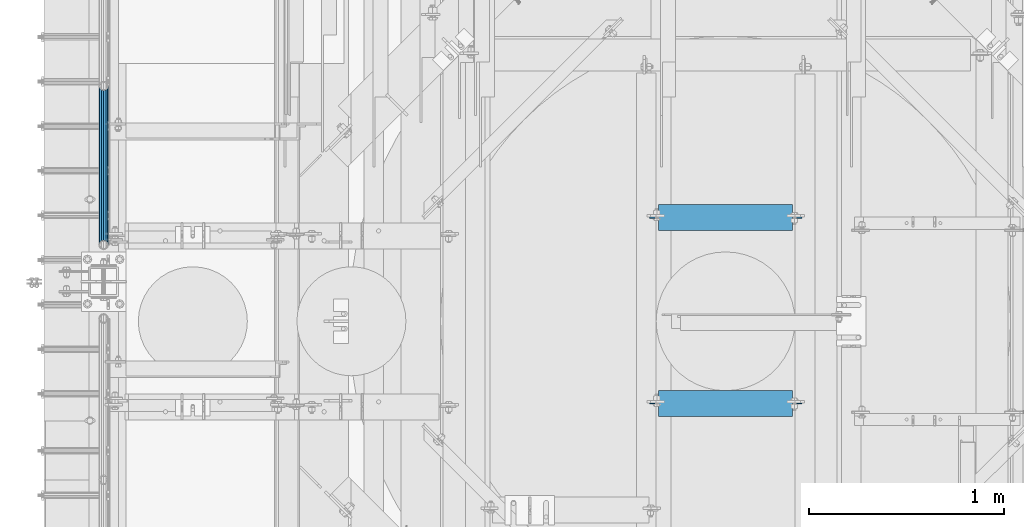
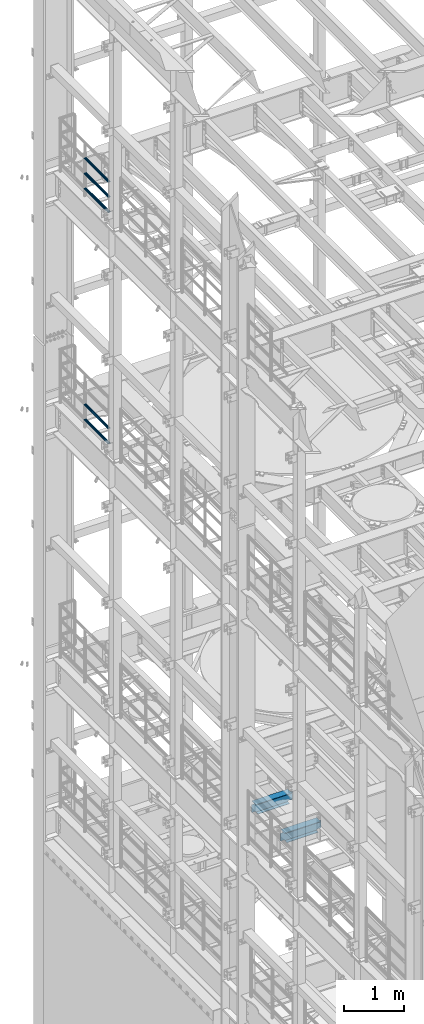
# One storey, part 1311 of 1876: 7 beams, 4 elements without a shape of their own.
"""IFC2X3 building model written with IfcOpenShell, lengths in millimetres."""

from ifc_helpers import new_model, si_unit, frame, origin_with_axes, place, context, subcontext, project, spatial, faceted_brep, material, type_object, element, aggregate, save


model = new_model("IFC2X3")

# Units and contexts
model_context = context("Model", 3, precision=1e-05, world=origin_with_axes())
body_context = subcontext(model_context, "Body", "Model", "MODEL_VIEW")
ifc_project = project(units=[si_unit("LENGTHUNIT", "METRE", prefix="MILLI"), si_unit("AREAUNIT", "SQUARE_METRE"), si_unit("VOLUMEUNIT", "CUBIC_METRE"), si_unit("MASSUNIT", "GRAM", prefix="KILO"), si_unit("TIMEUNIT", "SECOND"), si_unit("PLANEANGLEUNIT", "RADIAN"), si_unit("SOLIDANGLEUNIT", "STERADIAN"), si_unit("THERMODYNAMICTEMPERATUREUNIT", "DEGREE_CELSIUS"), si_unit("LUMINOUSINTENSITYUNIT", "LUMEN")], contexts=[model_context])

# Site, building, storey
site_placement = place(None, origin_with_axes())
site = spatial("IfcSite", under=ifc_project, at=site_placement, CompositionType="ELEMENT")
building_placement = place(site_placement, origin_with_axes())
building = spatial("IfcBuilding", under=site, at=building_placement, Name="Undefined", CompositionType="ELEMENT")
storey_placement = place(building_placement, origin_with_axes())
storey = spatial("IfcBuildingStorey", under=building, at=storey_placement, Name="Undefined", CompositionType="ELEMENT", Elevation=0.0)

# Assembly, beams
assembly_1_placement = place(storey_placement, origin_with_axes())
assembly_1 = element("IfcElementAssembly", 1, at=assembly_1_placement, inside=storey, Name="RAIL", AssemblyPlace="NOTDEFINED", PredefinedType="RIGID_FRAME")
ifc_material_1 = material()
beam_type_1 = type_object("IfcBeamType", Name="PIPE1-1/2SCH40", PredefinedType="NOTDEFINED")
beam_1_placement = place(assembly_1_placement, frame((-3.02406988339499e-11, 12686.3094, 18145.125), z_axis=(0.0, 0.0, 1.0), x_axis=(0.0, -1.0, 0.0)))
beam_1 = element("IfcBeam", 2, at=beam_1_placement, type_object=beam_type_1, material=ifc_material_1, Name="RAIL", ObjectType="PIPE1-1/2SCH40", context=body_context, shape_type="Brep", body=[
    faceted_brep([(792.499707006684, -12.0649999999996, 20.8971929933177), (792.499707006684, -12.0650000000314, 15.8661214311469), (792.006278568813, -10.2235000000001, 17.7076214311819), (789.266900000001, -9.09494701772928e-13, 20.4470000000001), (789.266900000001, -9.09494701772928e-13, 24.130000000001), (792.00627856883, 10.2235000000001, 17.7076214311819), (792.499707006684, 12.0649999999678, 15.8661214312124), (792.499707006684, 12.0649999999996, 20.8971929933177), (813.396900000002, 24.1300000000001, 0.0), (801.331900000001, 20.8971929933186, 12.0649999999987), (801.331900000001, 20.8971929933186, -12.0649999999987), (798.142328437896, 17.7076214311801, 10.2235000000001), (800.881707006714, 20.4470000000001, 0.0), (798.142328437896, 17.7076214311801, -10.2235000000001), (792.499707006684, 12.0649999999678, -15.8661214312124), (792.499707006684, 12.0649999999996, -20.8971929933177), (792.00627856883, 10.2235000000001, -17.7076214311819), (789.266900000001, 0.0, -20.4470000000001), (789.266900000001, 0.0, -24.130000000001), (792.499707006684, -12.0650000000314, -15.8661214311469), (792.499707006684, -12.0649999999996, -20.8971929933177), (792.006278568813, -10.2235000000001, -17.7076214311819), (813.396900000002, -24.1300000000319, 0.0), (801.331900000001, -20.8971929933186, -12.0649999999987), (801.331900000001, -20.8971929933186, 12.0649999999987), (798.142328437831, -17.7076214311801, -10.2235000000001), (800.881707006651, -20.4470000000001, 0.0), (798.142328437831, -17.7076214311801, 10.2235000000001), (12.0650000000064, -20.8971929933177, -12.0649999999987), (20.8971929933249, -12.0650000000005, -20.8971929933177), (0.0, 24.1299999999992, 0.0), (12.0650000000064, 20.8971929933177, -12.0649999999987), (12.0650000000064, 20.8971929933177, 12.0649999999987), (20.8971929933249, 12.0650000000005, 20.8971929933177), (24.1300000000064, 0.0, 24.130000000001), (20.8971929933249, 12.0650000000005, -20.8971929933177), (24.1300000000063, 0.0, -24.130000000001), (24.1300000000063, 0.0, -20.4470000000001), (20.8971929933249, -12.0650000000005, -15.8661214311796), (21.3906214311868, -10.2235000000001, -17.7076214311819), (21.3906214311868, 10.2235000000001, -17.7076214311819), (20.8971929933249, 12.0650000000005, -15.8661214311796), (15.2545715621445, 17.7076214311801, -10.2235000000001), (12.5151929933249, 20.4470000000001, 0.0), (15.2545715621445, 17.7076214311801, 10.2235000000001), (20.8971929933249, 12.0650000000005, 15.8661214311796), (21.3906214311868, 10.2235000000001, 17.7076214311819), (24.1300000000064, 0.0, 20.4470000000001), (21.3906214311868, -10.2235000000001, 17.7076214311819), (20.8971929933249, -12.0650000000005, 15.8661214311796), (20.8971929933249, -12.0650000000005, 20.8971929933177), (12.0650000000064, -20.8971929933177, 12.0649999999987), (0.0, -24.1299999999992, 0.0), (15.2545715621445, -17.7076214311801, 10.2235000000001), (12.5151929933249, -20.4470000000001, 0.0), (15.2545715621445, -17.7076214311801, -10.2235000000001)], [[[0, 1, 2, 3, 4]], [[4, 3, 5, 6, 7]], [[8, 9, 10]], [[7, 6, 11, 12, 13, 14, 15, 10, 9]], [[16, 17, 18, 15, 14]], [[19, 20, 18, 17, 21]], [[22, 23, 24]], [[24, 23, 20, 19, 25, 26, 27, 1, 0]], [[28, 29, 20, 23]], [[30, 31, 32]], [[33, 34, 4, 7]], [[32, 33, 7, 9]], [[30, 32, 9, 8]], [[31, 30, 8, 10]], [[35, 31, 10, 15]], [[36, 35, 15, 18]], [[29, 36, 18, 20]], [[37, 36, 29, 38, 39]], [[40, 41, 35, 36, 37]], [[32, 31, 35, 41, 42, 43, 44, 45, 33]], [[33, 45, 46, 47, 34]], [[34, 47, 48, 49, 50]], [[34, 50, 0, 4]], [[50, 51, 24, 0]], [[51, 52, 22, 24]], [[52, 28, 23, 22]], [[51, 28, 52]], [[50, 49, 53, 54, 55, 38, 29, 28, 51]], [[55, 54, 26, 25]], [[21, 39, 38, 55, 25, 19]], [[37, 39, 21, 17]], [[40, 37, 17, 16]], [[42, 41, 40, 16, 14, 13]], [[43, 42, 13, 12]], [[44, 43, 12, 11]], [[5, 46, 45, 44, 11, 6]], [[47, 46, 5, 3]], [[48, 47, 3, 2]], [[53, 49, 48, 2, 1, 27]], [[54, 53, 27, 26]]]),
])
beam_2_placement = place(assembly_1_placement, frame((-3.11501935357228e-11, 11872.9125, 18449.925), z_axis=(0.0, 0.0, -1.0), x_axis=(0.0, 1.0, 0.0)))
beam_2 = element("IfcBeam", 3, at=beam_2_placement, type_object=beam_type_1, material=ifc_material_1, Name="RAIL", ObjectType="PIPE1-1/2SCH40", context=body_context, shape_type="Brep", body=[
    faceted_brep([(0.0, 24.1299999999992, 0.0), (12.0650000000064, 20.8971929933177, -12.0649999999987), (12.0650000000064, 20.8971929933177, 12.0649999999987), (12.0650000000064, -20.8971929933177, 12.0649999999987), (12.0650000000064, -20.8971929933177, -12.0649999999987), (0.0, -24.1299999999992, 0.0), (20.8971929933249, -12.0650000000005, 20.8971929933177), (20.8971929933249, -12.0650000000005, 15.8661214311796), (15.2545715621445, -17.7076214311801, 10.2235000000001), (12.5151929933249, -20.4470000000001, 0.0), (15.2545715621445, -17.7076214311801, -10.2235000000001), (20.8971929933249, -12.0650000000005, -15.8661214311796), (20.8971929933249, -12.0650000000005, -20.8971929933177), (24.1300000000063, 0.0, -20.4470000000001), (24.1300000000063, 0.0, -24.130000000001), (21.3906214311868, -10.2235000000001, -17.7076214311819), (21.3906214311868, 10.2235000000001, -17.7076214311819), (20.8971929933249, 12.0650000000005, -15.8661214311796), (20.8971929933249, 12.0650000000005, -20.8971929933177), (15.2545715621445, 17.7076214311801, -10.2235000000001), (12.5151929933249, 20.4470000000001, 0.0), (15.2545715621445, 17.7076214311801, 10.2235000000001), (20.8971929933249, 12.0650000000005, 15.8661214311796), (20.8971929933249, 12.0650000000005, 20.8971929933177), (21.3906214311868, 10.2235000000001, 17.7076214311819), (24.1300000000064, 0.0, 20.4470000000001), (24.1300000000064, 0.0, 24.130000000001), (21.3906214311868, -10.2235000000001, 17.7076214311819), (813.396900000002, 24.1300000000001, 0.0), (801.331900000001, 20.8971929933186, -12.0649999999987), (792.499707006684, 12.0649999999996, -20.8971929933177), (813.396900000002, -24.1300000000319, 0.0), (801.331900000001, -20.8971929933186, -12.0649999999987), (801.331900000001, -20.8971929933186, 12.0649999999987), (792.499707006684, -12.0649999999996, 20.8971929933177), (792.499707006684, -12.0649999999996, -20.8971929933177), (789.266900000001, 0.0, -24.130000000001), (792.00627856883, 10.2235000000001, -17.7076214311819), (789.266900000001, 0.0, -20.4470000000001), (792.499707006684, 12.0649999999678, -15.8661214312124), (792.499707006684, -12.0650000000314, -15.8661214311469), (792.006278568813, -10.2235000000001, -17.7076214311819), (798.142328437831, -17.7076214311801, -10.2235000000001), (800.881707006651, -20.4470000000001, 0.0), (798.142328437831, -17.7076214311801, 10.2235000000001), (792.499707006684, -12.0650000000314, 15.8661214311469), (792.006278568813, -10.2235000000001, 17.7076214311819), (789.266900000001, -9.09494701772928e-13, 20.4470000000001), (789.266900000001, -9.09494701772928e-13, 24.130000000001), (792.499707006684, 12.0649999999996, 20.8971929933177), (801.331900000001, 20.8971929933186, 12.0649999999987), (792.499707006684, 12.0649999999678, 15.8661214312124), (798.142328437896, 17.7076214311801, 10.2235000000001), (800.881707006714, 20.4470000000001, 0.0), (798.142328437896, 17.7076214311801, -10.2235000000001), (792.00627856883, 10.2235000000001, 17.7076214311819)], [[[0, 1, 2]], [[3, 4, 5]], [[6, 7, 8, 9, 10, 11, 12, 4, 3]], [[13, 14, 12, 11, 15]], [[16, 17, 18, 14, 13]], [[2, 1, 18, 17, 19, 20, 21, 22, 23]], [[23, 22, 24, 25, 26]], [[26, 25, 27, 7, 6]], [[1, 0, 28, 29]], [[18, 1, 29, 30]], [[31, 32, 33]], [[6, 3, 33, 34]], [[3, 5, 31, 33]], [[5, 4, 32, 31]], [[4, 12, 35, 32]], [[12, 14, 36, 35]], [[14, 18, 30, 36]], [[37, 38, 36, 30, 39]], [[40, 35, 36, 38, 41]], [[33, 32, 35, 40, 42, 43, 44, 45, 34]], [[34, 45, 46, 47, 48]], [[26, 6, 34, 48]], [[2, 23, 49, 50]], [[23, 26, 48, 49]], [[0, 2, 50, 28]], [[28, 50, 29]], [[49, 51, 52, 53, 54, 39, 30, 29, 50]], [[48, 47, 55, 51, 49]], [[25, 24, 55, 47]], [[55, 24, 22, 21, 52, 51]], [[21, 20, 53, 52]], [[20, 19, 54, 53]], [[19, 17, 16, 37, 39, 54]], [[16, 13, 38, 37]], [[13, 15, 41, 38]], [[41, 15, 11, 10, 42, 40]], [[10, 9, 43, 42]], [[9, 8, 44, 43]], [[8, 7, 27, 46, 45, 44]], [[27, 25, 47, 46]]]),
])
beam_3_placement = place(assembly_1_placement, frame((-3.11501935357228e-11, 11872.9125, 18754.725), z_axis=(0.0, 0.0, -1.0), x_axis=(0.0, 1.0, 0.0)))
beam_3 = element("IfcBeam", 4, at=beam_3_placement, type_object=beam_type_1, material=ifc_material_1, Name="RAIL", ObjectType="PIPE1-1/2SCH40", context=body_context, shape_type="Brep", body=[
    faceted_brep([(0.0, 24.1299999999992, 0.0), (12.0650000000064, 20.8971929933177, -12.0649999999987), (12.0650000000064, 20.8971929933177, 12.0649999999987), (12.0650000000064, -20.8971929933177, 12.0649999999987), (12.0650000000064, -20.8971929933177, -12.0649999999987), (0.0, -24.1299999999992, 0.0), (20.8971929933249, -12.0650000000005, 20.8971929933177), (20.8971929933249, -12.0650000000005, 15.8661214311796), (15.2545715621445, -17.7076214311801, 10.2235000000001), (12.5151929933249, -20.4470000000001, 0.0), (15.2545715621445, -17.7076214311801, -10.2235000000001), (20.8971929933249, -12.0650000000005, -15.8661214311796), (20.8971929933249, -12.0650000000005, -20.8971929933177), (24.1300000000063, 0.0, -20.4470000000001), (24.1300000000063, 0.0, -24.130000000001), (21.3906214311868, -10.2235000000001, -17.7076214311819), (21.3906214311868, 10.2235000000001, -17.7076214311819), (20.8971929933249, 12.0650000000005, -15.8661214311796), (20.8971929933249, 12.0650000000005, -20.8971929933177), (15.2545715621445, 17.7076214311801, -10.2235000000001), (12.5151929933249, 20.4470000000001, 0.0), (15.2545715621445, 17.7076214311801, 10.2235000000001), (20.8971929933249, 12.0650000000005, 15.8661214311796), (20.8971929933249, 12.0650000000005, 20.8971929933177), (21.3906214311868, 10.2235000000001, 17.7076214311819), (24.1300000000064, 0.0, 20.4470000000001), (24.1300000000064, 0.0, 24.130000000001), (21.3906214311868, -10.2235000000001, 17.7076214311819), (813.396900000002, 24.1300000000001, 0.0), (801.331900000001, 20.8971929933186, -12.0649999999987), (792.499707006684, 12.0649999999996, -20.8971929933177), (813.396900000002, -24.1300000000319, 0.0), (801.331900000001, -20.8971929933186, -12.0649999999987), (801.331900000001, -20.8971929933186, 12.0649999999987), (792.499707006684, -12.0649999999996, 20.8971929933177), (792.499707006684, -12.0649999999996, -20.8971929933177), (789.266900000001, 0.0, -24.130000000001), (792.00627856883, 10.2235000000001, -17.7076214311819), (789.266900000001, 0.0, -20.4470000000001), (792.499707006684, 12.0649999999678, -15.8661214312124), (792.499707006684, -12.0650000000314, -15.8661214311469), (792.006278568813, -10.2235000000001, -17.7076214311819), (798.142328437831, -17.7076214311801, -10.2235000000001), (800.881707006651, -20.4470000000001, 0.0), (798.142328437831, -17.7076214311801, 10.2235000000001), (792.499707006684, -12.0650000000314, 15.8661214311469), (792.006278568813, -10.2235000000001, 17.7076214311819), (789.266900000001, -9.09494701772928e-13, 20.4470000000001), (789.266900000001, -9.09494701772928e-13, 24.130000000001), (792.499707006684, 12.0649999999996, 20.8971929933177), (801.331900000001, 20.8971929933186, 12.0649999999987), (792.499707006684, 12.0649999999678, 15.8661214312124), (798.142328437896, 17.7076214311801, 10.2235000000001), (800.881707006714, 20.4470000000001, 0.0), (798.142328437896, 17.7076214311801, -10.2235000000001), (792.00627856883, 10.2235000000001, 17.7076214311819)], [[[0, 1, 2]], [[3, 4, 5]], [[6, 7, 8, 9, 10, 11, 12, 4, 3]], [[13, 14, 12, 11, 15]], [[16, 17, 18, 14, 13]], [[2, 1, 18, 17, 19, 20, 21, 22, 23]], [[23, 22, 24, 25, 26]], [[26, 25, 27, 7, 6]], [[1, 0, 28, 29]], [[18, 1, 29, 30]], [[31, 32, 33]], [[6, 3, 33, 34]], [[3, 5, 31, 33]], [[5, 4, 32, 31]], [[4, 12, 35, 32]], [[12, 14, 36, 35]], [[14, 18, 30, 36]], [[37, 38, 36, 30, 39]], [[40, 35, 36, 38, 41]], [[33, 32, 35, 40, 42, 43, 44, 45, 34]], [[34, 45, 46, 47, 48]], [[26, 6, 34, 48]], [[2, 23, 49, 50]], [[23, 26, 48, 49]], [[0, 2, 50, 28]], [[28, 50, 29]], [[49, 51, 52, 53, 54, 39, 30, 29, 50]], [[48, 47, 55, 51, 49]], [[25, 24, 55, 47]], [[55, 24, 22, 21, 52, 51]], [[21, 20, 53, 52]], [[20, 19, 54, 53]], [[19, 17, 16, 37, 39, 54]], [[16, 13, 38, 37]], [[13, 15, 41, 38]], [[41, 15, 11, 10, 42, 40]], [[10, 9, 43, 42]], [[9, 8, 44, 43]], [[8, 7, 27, 46, 45, 44]], [[27, 25, 47, 46]]]),
])
aggregate(assembly_1, [beam_1, beam_2, beam_3])

assembly_2_placement = place(storey_placement, origin_with_axes())
assembly_2 = element("IfcElementAssembly", 5, at=assembly_2_placement, inside=storey, Name="RAIL", AssemblyPlace="NOTDEFINED", PredefinedType="RIGID_FRAME")
beam_4_placement = place(assembly_2_placement, frame((-3.02406988339499e-11, 12686.3094, 13471.525), z_axis=(0.0, 0.0, 1.0), x_axis=(0.0, -1.0, 0.0)))
beam_4 = element("IfcBeam", 6, at=beam_4_placement, type_object=beam_type_1, material=ifc_material_1, Name="RAIL", ObjectType="PIPE1-1/2SCH40", context=body_context, shape_type="Brep", body=[
    faceted_brep([(792.499707006684, -12.0649999999996, 20.8971929933177), (792.499707006684, -12.0650000000314, 15.8661214311469), (792.006278568813, -10.2235000000001, 17.7076214311819), (789.266900000001, -9.09494701772928e-13, 20.4470000000001), (789.266900000001, -9.09494701772928e-13, 24.130000000001), (792.00627856883, 10.2235000000001, 17.7076214311819), (792.499707006684, 12.0649999999678, 15.8661214312124), (792.499707006684, 12.0649999999996, 20.8971929933177), (813.396900000002, 24.1300000000001, 0.0), (801.331900000001, 20.8971929933186, 12.0649999999987), (801.331900000001, 20.8971929933186, -12.0649999999987), (798.142328437896, 17.7076214311801, 10.2235000000001), (800.881707006714, 20.4470000000001, 0.0), (798.142328437896, 17.7076214311801, -10.2235000000001), (792.499707006684, 12.0649999999678, -15.8661214312124), (792.499707006684, 12.0649999999996, -20.8971929933177), (792.00627856883, 10.2235000000001, -17.7076214311819), (789.266900000001, 0.0, -20.4470000000001), (789.266900000001, 0.0, -24.130000000001), (792.499707006684, -12.0650000000314, -15.8661214311469), (792.499707006684, -12.0649999999996, -20.8971929933177), (792.006278568813, -10.2235000000001, -17.7076214311819), (813.396900000002, -24.1300000000319, 0.0), (801.331900000001, -20.8971929933186, -12.0649999999987), (801.331900000001, -20.8971929933186, 12.0649999999987), (798.142328437831, -17.7076214311801, -10.2235000000001), (800.881707006651, -20.4470000000001, 0.0), (798.142328437831, -17.7076214311801, 10.2235000000001), (12.0650000000064, -20.8971929933177, -12.0649999999987), (20.8971929933249, -12.0650000000005, -20.8971929933177), (0.0, 24.1299999999992, 0.0), (12.0650000000064, 20.8971929933177, -12.0649999999987), (12.0650000000064, 20.8971929933177, 12.0649999999987), (20.8971929933249, 12.0650000000005, 20.8971929933177), (24.1300000000064, 0.0, 24.130000000001), (20.8971929933249, 12.0650000000005, -20.8971929933177), (24.1300000000063, 0.0, -24.130000000001), (24.1300000000063, 0.0, -20.4470000000001), (20.8971929933249, -12.0650000000005, -15.8661214311796), (21.3906214311868, -10.2235000000001, -17.7076214311819), (21.3906214311868, 10.2235000000001, -17.7076214311819), (20.8971929933249, 12.0650000000005, -15.8661214311796), (15.2545715621445, 17.7076214311801, -10.2235000000001), (12.5151929933249, 20.4470000000001, 0.0), (15.2545715621445, 17.7076214311801, 10.2235000000001), (20.8971929933249, 12.0650000000005, 15.8661214311796), (21.3906214311868, 10.2235000000001, 17.7076214311819), (24.1300000000064, 0.0, 20.4470000000001), (21.3906214311868, -10.2235000000001, 17.7076214311819), (20.8971929933249, -12.0650000000005, 15.8661214311796), (20.8971929933249, -12.0650000000005, 20.8971929933177), (12.0650000000064, -20.8971929933177, 12.0649999999987), (0.0, -24.1299999999992, 0.0), (15.2545715621445, -17.7076214311801, 10.2235000000001), (12.5151929933249, -20.4470000000001, 0.0), (15.2545715621445, -17.7076214311801, -10.2235000000001)], [[[0, 1, 2, 3, 4]], [[4, 3, 5, 6, 7]], [[8, 9, 10]], [[7, 6, 11, 12, 13, 14, 15, 10, 9]], [[16, 17, 18, 15, 14]], [[19, 20, 18, 17, 21]], [[22, 23, 24]], [[24, 23, 20, 19, 25, 26, 27, 1, 0]], [[28, 29, 20, 23]], [[30, 31, 32]], [[33, 34, 4, 7]], [[32, 33, 7, 9]], [[30, 32, 9, 8]], [[31, 30, 8, 10]], [[35, 31, 10, 15]], [[36, 35, 15, 18]], [[29, 36, 18, 20]], [[37, 36, 29, 38, 39]], [[40, 41, 35, 36, 37]], [[32, 31, 35, 41, 42, 43, 44, 45, 33]], [[33, 45, 46, 47, 34]], [[34, 47, 48, 49, 50]], [[34, 50, 0, 4]], [[50, 51, 24, 0]], [[51, 52, 22, 24]], [[52, 28, 23, 22]], [[51, 28, 52]], [[50, 49, 53, 54, 55, 38, 29, 28, 51]], [[55, 54, 26, 25]], [[21, 39, 38, 55, 25, 19]], [[37, 39, 21, 17]], [[40, 37, 17, 16]], [[42, 41, 40, 16, 14, 13]], [[43, 42, 13, 12]], [[44, 43, 12, 11]], [[5, 46, 45, 44, 11, 6]], [[47, 46, 5, 3]], [[48, 47, 3, 2]], [[53, 49, 48, 2, 1, 27]], [[54, 53, 27, 26]]]),
])
beam_5_placement = place(assembly_2_placement, frame((-3.11501935357228e-11, 11872.9125, 13776.325), z_axis=(0.0, 0.0, -1.0), x_axis=(0.0, 1.0, 0.0)))
beam_5 = element("IfcBeam", 7, at=beam_5_placement, type_object=beam_type_1, material=ifc_material_1, Name="RAIL", ObjectType="PIPE1-1/2SCH40", context=body_context, shape_type="Brep", body=[
    faceted_brep([(0.0, 24.1299999999992, 0.0), (12.0650000000064, 20.8971929933177, -12.0649999999987), (12.0650000000064, 20.8971929933177, 12.0649999999987), (12.0650000000064, -20.8971929933177, 12.0649999999987), (12.0650000000064, -20.8971929933177, -12.0649999999987), (0.0, -24.1299999999992, 0.0), (20.8971929933249, -12.0650000000005, 20.8971929933177), (20.8971929933249, -12.0650000000005, 15.8661214311796), (15.2545715621445, -17.7076214311801, 10.2235000000001), (12.5151929933249, -20.4470000000001, 0.0), (15.2545715621445, -17.7076214311801, -10.2235000000001), (20.8971929933249, -12.0650000000005, -15.8661214311796), (20.8971929933249, -12.0650000000005, -20.8971929933177), (24.1300000000063, 0.0, -20.4470000000001), (24.1300000000063, 0.0, -24.130000000001), (21.3906214311868, -10.2235000000001, -17.7076214311819), (21.3906214311868, 10.2235000000001, -17.7076214311819), (20.8971929933249, 12.0650000000005, -15.8661214311796), (20.8971929933249, 12.0650000000005, -20.8971929933177), (15.2545715621445, 17.7076214311801, -10.2235000000001), (12.5151929933249, 20.4470000000001, 0.0), (15.2545715621445, 17.7076214311801, 10.2235000000001), (20.8971929933249, 12.0650000000005, 15.8661214311796), (20.8971929933249, 12.0650000000005, 20.8971929933177), (21.3906214311868, 10.2235000000001, 17.7076214311819), (24.1300000000064, 0.0, 20.4470000000001), (24.1300000000064, 0.0, 24.130000000001), (21.3906214311868, -10.2235000000001, 17.7076214311819), (813.396900000002, 24.1300000000001, 0.0), (801.331900000001, 20.8971929933186, -12.0649999999987), (792.499707006684, 12.0649999999996, -20.8971929933177), (813.396900000002, -24.1300000000319, 0.0), (801.331900000001, -20.8971929933186, -12.0649999999987), (801.331900000001, -20.8971929933186, 12.0649999999987), (792.499707006684, -12.0649999999996, 20.8971929933177), (792.499707006684, -12.0649999999996, -20.8971929933177), (789.266900000001, 0.0, -24.130000000001), (792.00627856883, 10.2235000000001, -17.7076214311819), (789.266900000001, 0.0, -20.4470000000001), (792.499707006684, 12.0649999999678, -15.8661214312124), (792.499707006684, -12.0650000000314, -15.8661214311469), (792.006278568813, -10.2235000000001, -17.7076214311819), (798.142328437831, -17.7076214311801, -10.2235000000001), (800.881707006651, -20.4470000000001, 0.0), (798.142328437831, -17.7076214311801, 10.2235000000001), (792.499707006684, -12.0650000000314, 15.8661214311469), (792.006278568813, -10.2235000000001, 17.7076214311819), (789.266900000001, -9.09494701772928e-13, 20.4470000000001), (789.266900000001, -9.09494701772928e-13, 24.130000000001), (792.499707006684, 12.0649999999996, 20.8971929933177), (801.331900000001, 20.8971929933186, 12.0649999999987), (792.499707006684, 12.0649999999678, 15.8661214312124), (798.142328437896, 17.7076214311801, 10.2235000000001), (800.881707006714, 20.4470000000001, 0.0), (798.142328437896, 17.7076214311801, -10.2235000000001), (792.00627856883, 10.2235000000001, 17.7076214311819)], [[[0, 1, 2]], [[3, 4, 5]], [[6, 7, 8, 9, 10, 11, 12, 4, 3]], [[13, 14, 12, 11, 15]], [[16, 17, 18, 14, 13]], [[2, 1, 18, 17, 19, 20, 21, 22, 23]], [[23, 22, 24, 25, 26]], [[26, 25, 27, 7, 6]], [[1, 0, 28, 29]], [[18, 1, 29, 30]], [[31, 32, 33]], [[6, 3, 33, 34]], [[3, 5, 31, 33]], [[5, 4, 32, 31]], [[4, 12, 35, 32]], [[12, 14, 36, 35]], [[14, 18, 30, 36]], [[37, 38, 36, 30, 39]], [[40, 35, 36, 38, 41]], [[33, 32, 35, 40, 42, 43, 44, 45, 34]], [[34, 45, 46, 47, 48]], [[26, 6, 34, 48]], [[2, 23, 49, 50]], [[23, 26, 48, 49]], [[0, 2, 50, 28]], [[28, 50, 29]], [[49, 51, 52, 53, 54, 39, 30, 29, 50]], [[48, 47, 55, 51, 49]], [[25, 24, 55, 47]], [[55, 24, 22, 21, 52, 51]], [[21, 20, 53, 52]], [[20, 19, 54, 53]], [[19, 17, 16, 37, 39, 54]], [[16, 13, 38, 37]], [[13, 15, 41, 38]], [[41, 15, 11, 10, 42, 40]], [[10, 9, 43, 42]], [[9, 8, 44, 43]], [[8, 7, 27, 46, 45, 44]], [[27, 25, 47, 46]]]),
])
aggregate(assembly_2, [beam_4, beam_5])

# Assembly, beam
assembly_3_placement = place(storey_placement, origin_with_axes())
assembly_3 = element("IfcElementAssembly", 8, at=assembly_3_placement, inside=storey, Name="BEAM", AssemblyPlace="NOTDEFINED", PredefinedType="RIGID_FRAME")
ifc_material_2 = material(Name="STEEL/A992")
beam_type_2 = type_object("IfcBeamType", Name="W8X18", PredefinedType="NOTDEFINED")
beam_6_placement = place(assembly_3_placement, frame((2806.7, 11059.3111717218, 5027.6125), z_axis=(0.0, 0.0, 1.0), x_axis=(1.0, 0.0, 0.0)))
beam_6 = element("IfcBeam", 9, at=beam_6_placement, type_object=beam_type_2, material=ifc_material_2, Name="BEAM", ObjectType="W8X18", context=body_context, shape_type="Brep", body=[
    faceted_brep([(682.625000000001, -3.17499999999927, -95.25), (682.625000000001, -66.6749999999993, -95.25), (682.625000000001, -66.6749999999993, -103.1875), (682.625000000001, 66.6749999999993, -103.1875), (682.625000000001, 66.6749999999993, -95.25), (682.625000000001, 3.17499999999927, -95.25), (682.625000000001, 3.17499999999927, -90.4874998092655), (682.625000000001, -3.17499999999927, -90.4874998092655), (683.591729922588, 3.17499999999927, -85.62742029122), (683.591729922588, -3.17499999999927, -85.62742029122), (686.344743823067, 3.17499999999927, -81.5072438230663), (686.344743823067, -3.17499999999927, -81.5072438230663), (690.464920291221, 3.17499999999927, -78.7542299225879), (690.464920291221, -3.17499999999927, -78.7542299225879), (695.324999809266, 3.17499999999927, -77.7875000000004), (695.324999809266, -3.17499999999927, -77.7875000000004), (771.525, -3.17499999999927, -77.7875000000004), (771.525, 3.17499999999927, -77.7875000000004), (38.1000000000008, 3.17499999999927, 95.25), (38.1000000000008, 66.6749999999993, 95.25), (723.900000000001, 66.6749999999993, 95.25), (723.900000000001, 3.17499999999927, 95.25), (79.3750000000009, -3.17499999999927, -90.4874998092655), (79.3750000000009, 3.17499999999927, -90.4874998092655), (79.3750000000009, 3.17499999999927, -95.25), (79.3750000000009, 66.6749999999993, -95.25), (79.3750000000009, 66.6749999999993, -103.1875), (79.3750000000009, -66.6749999999993, -103.1875), (79.3750000000009, -66.6749999999993, -95.25), (79.3750000000009, -3.17499999999927, -95.25), (78.4082700774129, -3.17499999999927, -85.62742029122), (78.4082700774129, 3.17499999999927, -85.62742029122), (75.6552561769349, -3.17499999999927, -81.5072438230663), (75.6552561769349, 3.17499999999927, -81.5072438230663), (71.5350797087813, -3.17499999999927, -78.7542299225879), (71.5350797087813, 3.17499999999927, -78.7542299225879), (66.6750001907358, -3.17499999999927, -77.7875000000004), (66.6750001907358, 3.17499999999927, -77.7875000000004), (-9.52500000000009, -3.17499999999927, -77.7875000000004), (-9.52500000000009, 3.17499999999927, -77.7875000000004), (-9.52500000000009, -3.17499999999927, 77.7874999999995), (-9.52500000000009, 3.17499999999927, 77.7874999999995), (25.4000001907357, -3.17499999999927, 77.7874999999995), (25.4000001907357, 3.17499999999927, 77.7874999999995), (30.2600797087812, -3.17499999999927, 78.754229922587), (30.2600797087812, 3.17499999999927, 78.754229922587), (34.3802561769348, -3.17499999999927, 81.5072438230654), (34.3802561769348, 3.17499999999927, 81.5072438230654), (37.1332700774128, -3.17499999999927, 85.6274202912191), (37.1332700774128, 3.17499999999927, 85.6274202912191), (38.1000000000008, -3.17499999999927, 90.4874998092646), (38.1000000000008, 3.17499999999927, 90.4874998092646), (38.1000000000008, -66.6749999999993, 103.1875), (38.1000000000008, 66.6749999999993, 103.1875), (38.1000000000008, -3.17499999999927, 95.25), (38.1000000000008, -66.6749999999993, 95.25), (723.900000000001, -3.17499999999927, 95.25), (723.900000000001, -66.6749999999993, 95.25), (723.900000000001, -66.6749999999993, 103.1875), (723.900000000001, 66.6749999999993, 103.1875), (723.900000000001, -3.17499999999927, 90.4874998092646), (723.900000000001, 3.17499999999927, 90.4874998092646), (724.866729922589, -3.17499999999927, 85.6274202912191), (724.866729922589, 3.17499999999927, 85.6274202912191), (727.619743823067, -3.17499999999927, 81.5072438230654), (727.619743823067, 3.17499999999927, 81.5072438230654), (731.739920291221, -3.17499999999927, 78.754229922587), (731.739920291221, 3.17499999999927, 78.754229922587), (736.599999809266, -3.17499999999927, 77.7874999999995), (736.599999809266, 3.17499999999927, 77.7874999999995), (771.525, -3.17499999999927, 77.7874999999995), (771.525, 3.17499999999927, 77.7874999999995)], [[[0, 1, 2, 3, 4, 5, 6, 7]], [[7, 6, 8, 9]], [[9, 8, 10, 11]], [[11, 10, 12, 13]], [[13, 12, 14, 15]], [[16, 15, 14, 17]], [[18, 19, 20, 21]], [[22, 23, 24, 25, 26, 27, 28, 29]], [[30, 31, 23, 22]], [[32, 33, 31, 30]], [[34, 35, 33, 32]], [[36, 37, 35, 34]], [[38, 39, 37, 36]], [[40, 41, 39, 38]], [[42, 43, 41, 40]], [[44, 45, 43, 42]], [[46, 47, 45, 44]], [[48, 49, 47, 46]], [[50, 51, 49, 48]], [[52, 53, 19, 18, 51, 50, 54, 55]], [[55, 54, 56, 57]], [[52, 55, 57, 58]], [[53, 52, 58, 59]], [[19, 53, 59, 20]], [[58, 57, 56, 60, 61, 21, 20, 59]], [[62, 63, 61, 60]], [[64, 65, 63, 62]], [[66, 67, 65, 64]], [[68, 69, 67, 66]], [[70, 71, 69, 68]], [[71, 70, 16, 17]], [[12, 10, 8, 6, 5, 24, 23, 31, 33, 35, 37, 39, 41, 43, 45, 47, 49, 51, 18, 21, 61, 63, 65, 67, 69, 71, 17, 14]], [[25, 24, 5, 4]], [[26, 25, 4, 3]], [[27, 26, 3, 2]], [[28, 27, 2, 1]], [[29, 28, 1, 0]], [[70, 68, 66, 64, 62, 60, 56, 54, 50, 48, 46, 44, 42, 40, 38, 36, 34, 32, 30, 22, 29, 0, 7, 9, 11, 13, 15, 16]]]),
])
aggregate(assembly_3, [beam_6])

assembly_4_placement = place(storey_placement, origin_with_axes())
assembly_4 = element("IfcElementAssembly", 10, at=assembly_4_placement, inside=storey, Name="BEAM", AssemblyPlace="NOTDEFINED", PredefinedType="RIGID_FRAME")
beam_7_placement = place(assembly_4_placement, frame((2806.7, 12011.8111717218, 5027.6125), z_axis=(0.0, 0.0, 1.0), x_axis=(1.0, 0.0, 0.0)))
beam_7 = element("IfcBeam", 11, at=beam_7_placement, type_object=beam_type_2, material=ifc_material_2, Name="BEAM", ObjectType="W8X18", context=body_context, shape_type="Brep", body=[
    faceted_brep([(682.625000000001, -3.17499999999927, -95.25), (682.625000000001, -66.6749999999993, -95.25), (682.625000000001, -66.6749999999993, -103.1875), (682.625000000001, 66.6749999999993, -103.1875), (682.625000000001, 66.6749999999993, -95.25), (682.625000000001, 3.17499999999927, -95.25), (682.625000000001, 3.17499999999927, -90.4874998092655), (682.625000000001, -3.17499999999927, -90.4874998092655), (683.591729922588, 3.17499999999927, -85.62742029122), (683.591729922588, -3.17499999999927, -85.62742029122), (686.344743823067, 3.17499999999927, -81.5072438230663), (686.344743823067, -3.17499999999927, -81.5072438230663), (690.464920291221, 3.17499999999927, -78.7542299225879), (690.464920291221, -3.17499999999927, -78.7542299225879), (695.324999809266, 3.17499999999927, -77.7875000000004), (695.324999809266, -3.17499999999927, -77.7875000000004), (771.525, -3.17499999999927, -77.7875000000004), (771.525, 3.17499999999927, -77.7875000000004), (38.1000000000008, 3.17499999999927, 95.25), (38.1000000000008, 66.6749999999993, 95.25), (723.900000000001, 66.6749999999993, 95.25), (723.900000000001, 3.17499999999927, 95.25), (79.3750000000009, -3.17499999999927, -90.4874998092655), (79.3750000000009, 3.17499999999927, -90.4874998092655), (79.3750000000009, 3.17499999999927, -95.25), (79.3750000000009, 66.6749999999993, -95.25), (79.3750000000009, 66.6749999999993, -103.1875), (79.3750000000009, -66.6749999999993, -103.1875), (79.3750000000009, -66.6749999999993, -95.25), (79.3750000000009, -3.17499999999927, -95.25), (78.4082700774129, -3.17499999999927, -85.62742029122), (78.4082700774129, 3.17499999999927, -85.62742029122), (75.6552561769349, -3.17499999999927, -81.5072438230663), (75.6552561769349, 3.17499999999927, -81.5072438230663), (71.5350797087813, -3.17499999999927, -78.7542299225879), (71.5350797087813, 3.17499999999927, -78.7542299225879), (66.6750001907358, -3.17499999999927, -77.7875000000004), (66.6750001907358, 3.17499999999927, -77.7875000000004), (-9.52500000000009, -3.17499999999927, -77.7875000000004), (-9.52500000000009, 3.17499999999927, -77.7875000000004), (-9.52500000000009, -3.17499999999927, 77.7874999999995), (-9.52500000000009, 3.17499999999927, 77.7874999999995), (25.4000001907357, -3.17499999999927, 77.7874999999995), (25.4000001907357, 3.17499999999927, 77.7874999999995), (30.2600797087812, -3.17499999999927, 78.754229922587), (30.2600797087812, 3.17499999999927, 78.754229922587), (34.3802561769348, -3.17499999999927, 81.5072438230654), (34.3802561769348, 3.17499999999927, 81.5072438230654), (37.1332700774128, -3.17499999999927, 85.6274202912191), (37.1332700774128, 3.17499999999927, 85.6274202912191), (38.1000000000008, -3.17499999999927, 90.4874998092646), (38.1000000000008, 3.17499999999927, 90.4874998092646), (38.1000000000008, -66.6749999999993, 103.1875), (38.1000000000008, 66.6749999999993, 103.1875), (38.1000000000008, -3.17499999999927, 95.25), (38.1000000000008, -66.6749999999993, 95.25), (723.900000000001, -3.17499999999927, 95.25), (723.900000000001, -66.6749999999993, 95.25), (723.900000000001, -66.6749999999993, 103.1875), (723.900000000001, 66.6749999999993, 103.1875), (723.900000000001, -3.17499999999927, 90.4874998092646), (723.900000000001, 3.17499999999927, 90.4874998092646), (724.866729922589, -3.17499999999927, 85.6274202912191), (724.866729922589, 3.17499999999927, 85.6274202912191), (727.619743823067, -3.17499999999927, 81.5072438230654), (727.619743823067, 3.17499999999927, 81.5072438230654), (731.739920291221, -3.17499999999927, 78.754229922587), (731.739920291221, 3.17499999999927, 78.754229922587), (736.599999809266, -3.17499999999927, 77.7874999999995), (736.599999809266, 3.17499999999927, 77.7874999999995), (771.525, -3.17499999999927, 77.7874999999995), (771.525, 3.17499999999927, 77.7874999999995)], [[[0, 1, 2, 3, 4, 5, 6, 7]], [[7, 6, 8, 9]], [[9, 8, 10, 11]], [[11, 10, 12, 13]], [[13, 12, 14, 15]], [[16, 15, 14, 17]], [[18, 19, 20, 21]], [[22, 23, 24, 25, 26, 27, 28, 29]], [[30, 31, 23, 22]], [[32, 33, 31, 30]], [[34, 35, 33, 32]], [[36, 37, 35, 34]], [[38, 39, 37, 36]], [[40, 41, 39, 38]], [[42, 43, 41, 40]], [[44, 45, 43, 42]], [[46, 47, 45, 44]], [[48, 49, 47, 46]], [[50, 51, 49, 48]], [[52, 53, 19, 18, 51, 50, 54, 55]], [[55, 54, 56, 57]], [[52, 55, 57, 58]], [[53, 52, 58, 59]], [[19, 53, 59, 20]], [[58, 57, 56, 60, 61, 21, 20, 59]], [[62, 63, 61, 60]], [[64, 65, 63, 62]], [[66, 67, 65, 64]], [[68, 69, 67, 66]], [[70, 71, 69, 68]], [[71, 70, 16, 17]], [[12, 10, 8, 6, 5, 24, 23, 31, 33, 35, 37, 39, 41, 43, 45, 47, 49, 51, 18, 21, 61, 63, 65, 67, 69, 71, 17, 14]], [[25, 24, 5, 4]], [[26, 25, 4, 3]], [[27, 26, 3, 2]], [[28, 27, 2, 1]], [[29, 28, 1, 0]], [[70, 68, 66, 64, 62, 60, 56, 54, 50, 48, 46, 44, 42, 40, 38, 36, 34, 32, 30, 22, 29, 0, 7, 9, 11, 13, 15, 16]]]),
])
aggregate(assembly_4, [beam_7])

save(model, "model.ifc")
